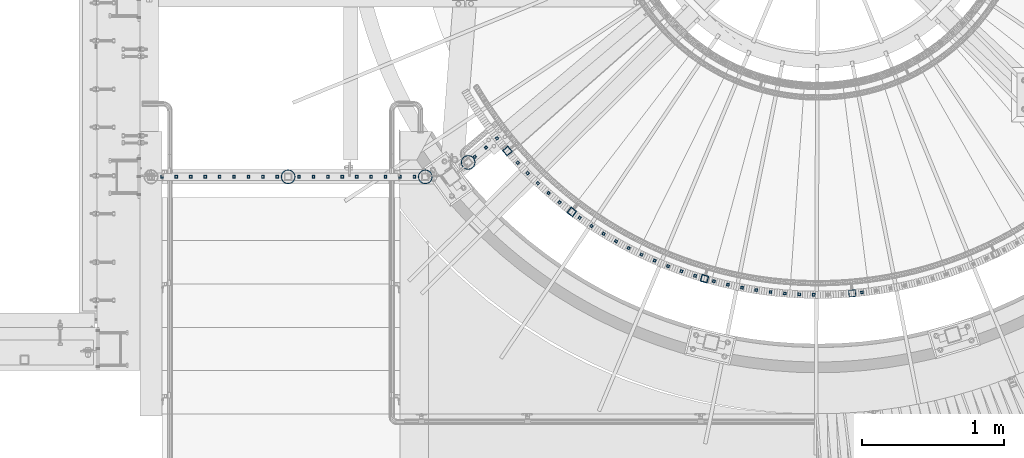
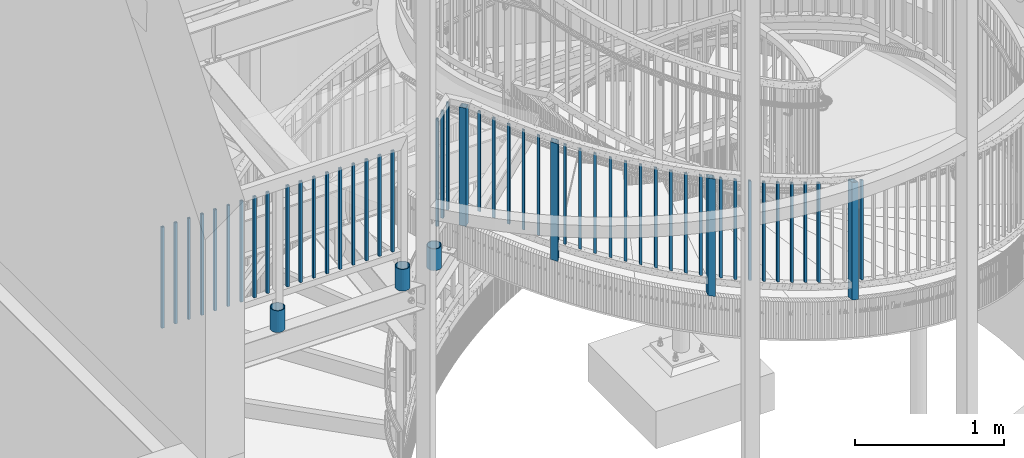
# One storey, part 254 of 975: 52 columns.
"""IFC2X3 building model written with IfcOpenShell, lengths in millimetres."""

from ifc_helpers import new_model, si_unit, frame, origin_with_axes, place, context, subcontext, project, spatial, faceted_brep, material, type_object, element, save


model = new_model("IFC2X3")

# Units and contexts
model_context = context("Model", 3, precision=1e-05, world=origin_with_axes())
body_context = subcontext(model_context, "Body", "Model", "MODEL_VIEW")
ifc_project = project(units=[si_unit("LENGTHUNIT", "METRE", prefix="MILLI"), si_unit("AREAUNIT", "SQUARE_METRE"), si_unit("VOLUMEUNIT", "CUBIC_METRE"), si_unit("MASSUNIT", "GRAM", prefix="KILO"), si_unit("TIMEUNIT", "SECOND"), si_unit("PLANEANGLEUNIT", "RADIAN"), si_unit("SOLIDANGLEUNIT", "STERADIAN"), si_unit("THERMODYNAMICTEMPERATUREUNIT", "DEGREE_CELSIUS"), si_unit("LUMINOUSINTENSITYUNIT", "LUMEN")], contexts=[model_context])

# Site, building, storey
site_placement = place(None, origin_with_axes())
site = spatial("IfcSite", under=ifc_project, at=site_placement, CompositionType="ELEMENT")
building_placement = place(site_placement, origin_with_axes())
building = spatial("IfcBuilding", under=site, at=building_placement, Name="Undefined", CompositionType="ELEMENT")
storey_placement = place(building_placement, origin_with_axes())
storey = spatial("IfcBuildingStorey", under=building, at=storey_placement, Name="Undefined", CompositionType="ELEMENT", Elevation=0.0)

# Columns
ifc_material_1 = material()
column_type_1 = type_object("IfcColumnType", Name="HSS3/4X3/4X.120_TUBES", PredefinedType="NOTDEFINED")
for number, where, z_axis, x_axis, name in (
    (1, (32472.7728355411, 1636.53479367322, 4229.09995262131), (-0.765022466002439, -0.644003592002053, 0.0), (0.0, 0.0, 1.0), "PICKET"),
    (2, (32395.0465529952, 1571.10402872579, 4229.09995262131), (-0.765022466002439, -0.644003592002053, 0.0), (0.0, 0.0, 1.0), "PICKET"),
    (3, (32317.3202704494, 1505.67326377838, 4229.09995262131), (-0.765022466002439, -0.644003592002053, 0.0), (0.0, 0.0, 1.0), "PICKET"),
):
    element("IfcColumn", number, at=place(storey_placement, frame(where, z_axis=z_axis, x_axis=x_axis)), inside=storey, type_object=column_type_1, material=ifc_material_1, Name=name, ObjectType="HSS3/4X3/4X.120_TUBES", context=body_context, shape_type="Brep", body=[
        faceted_brep([(0.0, 6.34999999998763, -6.34999999998763), (0.0, -6.35000000000582, -6.34999999998763), (876.3, -6.35000000000218, -6.3500000000131), (876.3, 6.34999999999854, -6.35000000000946), (0.0, -6.34999999998763, 6.34999999998763), (876.3, -6.34999999999854, 6.34999999999127), (0.0, 6.35000000000946, 6.34999999998763), (876.3, 6.35000000000582, 6.34999999999491), (0.0, 9.52499999997963, -9.52499999997963), (0.0, 9.52500000000873, 9.5249999999869), (876.3, 9.52500000000146, 9.52499999999418), (876.3, 9.52499999999782, -9.52500000001237), (0.0, -9.52499999997963, 9.52499999998327), (876.3, -9.52499999999782, 9.52499999999054), (0.0, -9.52500000000873, -9.5249999999869), (876.3, -9.52500000000146, -9.52500000001237)], [[[0, 1, 2, 3]], [[1, 4, 5, 2]], [[4, 6, 7, 5]], [[6, 0, 3, 7]], [[8, 9, 10, 11]], [[9, 12, 13, 10]], [[12, 14, 15, 13]], [[14, 8, 11, 15]], [[13, 15, 11, 10], [5, 7, 3, 2]], [[14, 12, 9, 8], [6, 4, 1, 0]]]),
    ])
for number, where, z_axis, x_axis, name in (
    (4, (32618.921052414, 1464.08237529478, 4224.3312401068), (-0.736967996847281, -0.675927637859931, 0.0), (0.0, 0.0, 1.0), "PICKET"),
    (5, (32688.8815704204, 1390.43131860672, 4192.1843651068), (-0.712586748242553, -0.701584012238808, 0.0), (0.0, 0.0, 1.0), "PICKET"),
    (6, (32761.4046241084, 1319.30214797491, 4159.8390531068), (-0.687312845930432, -0.726361515926478, 0.0), (0.0, 0.0, 1.0), "PICKET"),
    (7, (32836.3993642215, 1250.78396654568, 4127.6921781068), (-0.66117795031155, -0.750229110353509, 0.0), (0.0, 0.0, 1.0), "PICKET"),
    (8, (32913.7718452344, 1184.96260669257, 4095.3468661068), (-0.634214800026097, -0.773156897031811, 0.0), (0.0, 0.0, 1.0), "PICKET"),
    (9, (33055.3764509613, 1075.95161443596, 4038.5937811068), (-0.584868572966661, -0.811128073953763, 0.0), (0.0, 0.0, 1.0), "PICKET"),
    (10, (34001.0576996427, 628.808966037676, 3704.2368493963), (-0.255339545942544, -0.966851444782421, 0.0), (0.0, 0.0, 1.0), "PICKET"),
    (11, (35044.1809236989, 550.155456184198, 3369.73696094143), (0.10810760998162, -0.994139197830999, 0.0), (0.0, 0.0, 1.0), "PICKET"),
    (12, (33138.7987237243, 1017.98889677892, 4006.2484691068), (-0.55579813310099, -0.831317289151052, 0.0), (0.0, 0.0, 1.0), "PICKET"),
    (13, (34099.7110809052, 604.591976202849, 3671.8915373963), (-0.220964785922006, -0.975281786655755, 0.0), (0.0, 0.0, 1.0), "PICKET"),
    (14, (33224.2199232644, 963.014621883565, 3973.9031571068), (-0.526031448126563, -0.850465117204621, 0.0), (0.0, 0.0, 1.0), "PICKET"),
    (15, (34199.1596589761, 583.881289326423, 3639.5462253963), (-0.186313223072022, -0.982490398379809, 0.0), (0.0, 0.0, 1.0), "PICKET"),
    (16, (33311.5330428842, 911.097655741369, 3941.5578451068), (-0.495605806811865, -0.868547571670292, 0.0), (0.0, 0.0, 1.0), "PICKET"),
    (17, (34299.2788551328, 566.702849579355, 3607.2009133963), (-0.151428267050898, -0.988468249332249, 0.0), (0.0, 0.0, 1.0), "PICKET"),
    (18, (33400.6287058876, 862.30303446887, 3909.2125331068), (-0.464559322187641, -0.885542001357677, 0.0), (0.0, 0.0, 1.0), "PICKET"),
    (19, (34399.9432505731, 553.078176304787, 3574.8556013963), (-0.116353618016888, -0.99320785114415, 0.0), (0.0, 0.0, 1.0), "PICKET"),
    (20, (33491.3953025959, 816.691882837225, 3876.8672211068), (-0.432930886148133, -0.901427117308433, 0.0), (0.0, 0.0, 1.0), "PICKET"),
    (21, (34501.0267435266, 543.024337060864, 3542.5102893963), (-0.0811332129715956, -0.996703266651066, 0.0), (0.0, 0.0, 1.0), "PICKET"),
    (22, (33583.7191301599, 774.321337701564, 3844.5219091068), (-0.400760120016283, -0.916183020037228, 0.0), (0.0, 0.0, 1.0), "PICKET"),
    (23, (34602.4027072213, 536.553926240314, 3510.1649773963), (-0.0458111720060842, -0.998950117132697, 0.0), (0.0, 0.0, 1.0), "PICKET"),
    (24, (33677.4845349956, 735.244476425897, 3812.1765971068), (-0.36808732396752, -0.929791224917954, 0.0), (0.0, 0.0, 1.0), "PICKET"),
    (25, (34703.9441485088, 533.675049293503, 3477.8196653963), (-0.0104317449986193, -0.999945587867802, 0.0), (0.0, 0.0, 1.0), "PICKET"),
    (26, (33772.5740576626, 699.510250393418, 3779.8312851068), (-0.334953427020751, -0.942234685058375, 0.0), (0.0, 0.0, 1.0), "PICKET"),
    (27, (33868.8685800047, 667.163423685329, 3747.4859731068), (-0.301399934967783, -0.953497812898077, 0.0), (0.0, 0.0, 1.0), "PICKET"),
):
    element("IfcColumn", number, at=place(storey_placement, frame(where, z_axis=z_axis, x_axis=x_axis)), inside=storey, type_object=column_type_1, material=ifc_material_1, Name=name, ObjectType="HSS3/4X3/4X.120_TUBES", context=body_context, shape_type="Brep", body=[
        faceted_brep([(48.9778304891588, 6.35000000000036, -6.34999999999854), (44.9444858438005, -6.35000000000582, -6.34999999999127), (858.946568247068, -6.35000000000582, -6.34999999999127), (863.063419332087, 6.35000000000036, -6.34999999999854), (44.9444858438051, -6.35000000000036, 6.35000000000582), (858.946568247072, -6.35000000000036, 6.35000000000582), (48.9778304891634, 6.350000000004, 6.34999999999854), (863.063419332091, 6.350000000004, 6.34999999999854), (49.9861666504976, 9.52499999999964, -9.52500000000146), (49.9861666505039, 9.52500000000691, 9.52499999999418), (864.092632103347, 9.52500000000691, 9.52499999999418), (864.09263210334, 9.52499999999964, -9.52500000000146), (43.9361496824667, -9.52500000000146, 9.52500000001601), (857.917355475819, -9.52500000000146, 9.52500000001601), (43.9361496824599, -9.52500000000691, -9.52499999997963), (857.917355475812, -9.52500000000691, -9.52499999997963)], [[[0, 1, 2, 3]], [[1, 4, 5, 2]], [[4, 6, 7, 5]], [[6, 0, 3, 7]], [[8, 9, 10, 11]], [[9, 12, 13, 10]], [[12, 14, 15, 13]], [[14, 8, 11, 15]], [[13, 15, 11, 10], [5, 7, 3, 2]], [[14, 12, 9, 8], [6, 4, 1, 0]]]),
    ])
for number, where, z_axis, x_axis, name in (
    (28, (31890.8704303168, 1364.92410933259, 4254.49990684305), (1.0, 0.0, 0.0), (0.0, 0.0, 1.0), "PICKET"),
    (29, (31789.2704303168, 1364.92410933259, 4254.49990684305), (1.0, 0.0, 0.0), (0.0, 0.0, 1.0), "PICKET"),
    (30, (31687.6704303168, 1364.92410933259, 4254.49990684305), (1.0, 0.0, 0.0), (0.0, 0.0, 1.0), "PICKET"),
    (31, (31586.0704303168, 1364.92410933259, 4254.49990684305), (1.0, 0.0, 0.0), (0.0, 0.0, 1.0), "PICKET"),
    (32, (31484.4704303168, 1364.92410933259, 4254.49990684305), (1.0, 0.0, 0.0), (0.0, 0.0, 1.0), "PICKET"),
    (33, (31382.8704303168, 1364.92410933259, 4254.49990684305), (1.0, 0.0, 0.0), (0.0, 0.0, 1.0), "PICKET"),
    (34, (31281.2704303168, 1364.92410933259, 4254.49990684305), (1.0, 0.0, 0.0), (0.0, 0.0, 1.0), "PICKET"),
    (35, (31179.6704303168, 1364.92410933259, 4254.49990684305), (1.0, 0.0, 0.0), (0.0, 0.0, 1.0), "PICKET"),
    (36, (31078.0704303168, 1364.92410933259, 4254.49990684305), (1.0, 0.0, 0.0), (0.0, 0.0, 1.0), "PICKET"),
    (37, (30924.8901221104, 1364.93166525738, 4254.49996145182), (1.0, 0.0, 0.0), (0.0, 0.0, 1.0), "PICKET"),
    (38, (30823.2901221104, 1364.93166525738, 4254.49996145182), (1.0, 0.0, 0.0), (0.0, 0.0, 1.0), "PICKET"),
    (39, (30721.6901221104, 1364.93166525738, 4254.49996145182), (1.0, 0.0, 0.0), (0.0, 0.0, 1.0), "PICKET"),
    (40, (30620.0901221104, 1364.93166525738, 4254.49996145182), (1.0, 0.0, 0.0), (0.0, 0.0, 1.0), "PICKET"),
    (41, (30518.4901221104, 1364.93166525738, 4254.49996145182), (1.0, 0.0, 0.0), (0.0, 0.0, 1.0), "PICKET"),
    (42, (30416.8901221104, 1364.93166525738, 4254.49996145182), (1.0, 0.0, 0.0), (0.0, 0.0, 1.0), "PICKET"),
    (43, (30315.2901221104, 1364.93166525738, 4254.49996145182), (1.0, 0.0, 0.0), (0.0, 0.0, 1.0), "PICKET"),
    (44, (30213.6901221104, 1364.93166525738, 4254.49996145182), (1.0, 0.0, 0.0), (0.0, 0.0, 1.0), "PICKET"),
    (45, (30112.0901221104, 1364.93166525738, 4254.49996145182), (1.0, 0.0, 0.0), (0.0, 0.0, 1.0), "PICKET"),
):
    element("IfcColumn", number, at=place(storey_placement, frame(where, z_axis=z_axis, x_axis=x_axis)), inside=storey, type_object=column_type_1, material=ifc_material_1, Name=name, ObjectType="HSS3/4X3/4X.120_TUBES", context=body_context, shape_type="Brep", body=[
        faceted_brep([(0.0, 6.34999999998763, -6.34999999998763), (0.0, -6.35000000000582, -6.34999999998763), (825.49997943247, -6.35000000000582, -6.34999999998763), (825.49997943247, 6.34999999998763, -6.34999999998763), (0.0, -6.34999999998763, 6.34999999998763), (825.49997943247, -6.34999999998763, 6.34999999998763), (0.0, 6.35000000000946, 6.34999999998763), (825.49997943247, 6.35000000000946, 6.34999999998763), (0.0, 9.52499999997963, -9.52499999997963), (0.0, 9.52500000000873, 9.5249999999869), (825.49997943247, 9.52500000000873, 9.5249999999869), (825.49997943247, 9.52499999997963, -9.52499999997963), (0.0, -9.52499999997963, 9.52499999998327), (825.49997943247, -9.52499999997963, 9.52499999998327), (0.0, -9.52500000000873, -9.5249999999869), (825.49997943247, -9.52500000000873, -9.5249999999869)], [[[0, 1, 2, 3]], [[1, 4, 5, 2]], [[4, 6, 7, 5]], [[6, 0, 3, 7]], [[8, 9, 10, 11]], [[9, 12, 13, 10]], [[12, 14, 15, 13]], [[14, 8, 11, 15]], [[13, 15, 11, 10], [5, 7, 3, 2]], [[14, 12, 9, 8], [6, 4, 1, 0]]]),
    ])
column_type_2 = type_object("IfcColumnType", Name="HSS2X2X.188_TUBES", PredefinedType="NOTDEFINED")
for number, where, z_axis, x_axis, name in (
    (46, (32999.9820526721, 1116.79097201019, 3906.48311287522), (-0.604319542031932, -0.796742048042098, 0.0), (0.0, 0.0, 1.0), "HANDRAIL"),
    (47, (33934.7070575041, 647.084212052728, 3572.11593587522), (-0.278654082022891, -0.960391536078895, 0.0), (0.0, 0.0, 1.0), "HANDRAIL"),
    (48, (34975.6758745477, 543.550658189336, 3237.55032187522), (0.0840275489872219, -0.996463431848455, 0.0), (0.0, 0.0, 1.0), "HANDRAIL"),
):
    element("IfcColumn", number, at=place(storey_placement, frame(where, z_axis=z_axis, x_axis=x_axis)), inside=storey, type_object=column_type_2, material=ifc_material_1, Name=name, ObjectType="HSS2X2X.188_TUBES", context=body_context, shape_type="Brep", body=[
        faceted_brep([(59.7770034089217, 20.6374999999425, -20.6375000000444), (46.6339334019876, -20.6375000000517, -20.6375000000335), (1006.79125658838, -20.6375000000517, -20.6375000000335), (1019.96851403156, 20.6374999999425, -20.6375000000444), (46.6339334020035, -20.6374999999389, 20.637500000048), (1006.7912565884, -20.6374999999389, 20.637500000048), (59.7770034089381, 20.6375000000517, 20.6375000000335), (1019.96851403158, 20.6375000000517, 20.6375000000335), (61.2935114866432, 25.3999999999287, -25.4000000000524), (61.2935114866632, 25.4000000000633, 25.4000000000415), (1021.48896681348, 25.4000000000633, 25.4000000000415), (1021.48896681346, 25.3999999999287, -25.4000000000524), (45.1174253242825, -25.3999999999251, 25.400000000056), (1005.27080380649, -25.3999999999251, 25.400000000056), (45.1174253242625, -25.4000000000597, -25.4000000000415), (1005.27080380647, -25.4000000000597, -25.4000000000415)], [[[0, 1, 2, 3]], [[1, 4, 5, 2]], [[4, 6, 7, 5]], [[6, 0, 3, 7]], [[8, 9, 10, 11]], [[9, 12, 13, 10]], [[12, 14, 15, 13]], [[14, 8, 11, 15]], [[13, 15, 11, 10], [5, 7, 3, 2]], [[14, 12, 9, 8], [6, 4, 1, 0]]]),
    ])
column_1_placement = place(storey_placement, frame((32546.1374942593, 1546.41999163571, 4089.4), z_axis=(-0.762442511287587, -0.647055961244063, 0.0), x_axis=(0.0, 0.0, 1.0)))
element("IfcColumn", 49, at=column_1_placement, inside=storey, type_object=column_type_2, material=ifc_material_1, Name="HANDRAIL", ObjectType="HSS2X2X.188_TUBES", context=body_context, shape_type="Brep", body=[
    faceted_brep([(51.3320176729967, 20.6374999999716, -20.6375000000371), (51.3320175904473, -20.6374999999935, -20.6374999999898), (1016.0, -20.6374999999935, -20.6374999999898), (1016.0, 20.6374999999716, -20.6375000000371), (51.3320175904473, -20.6374999999716, 20.6375000000226), (1016.0, -20.6374999999716, 20.6375000000226), (51.3320176729967, 20.6374999999898, 20.6374999999789), (1016.0, 20.6374999999898, 20.6374999999789), (51.3320176825218, 25.3999999999651, -25.4000000000415), (51.3320176825218, 25.3999999999869, 25.3999999999724), (1016.00000000002, 25.4000000000087, 25.3999999999724), (1016.0, 25.3999999999651, -25.4000000000415), (51.3320175809222, -25.3999999999687, 25.4000000000306), (1016.00000000003, -25.4000000000087, 25.4000000000124), (51.3320175809222, -25.3999999999869, -25.3999999999833), (1016.0, -25.3999999999869, -25.3999999999833)], [[[0, 1, 2, 3]], [[1, 4, 5, 2]], [[4, 6, 7, 5]], [[6, 0, 3, 7]], [[8, 9, 10, 11]], [[9, 12, 13, 10]], [[12, 14, 15, 13]], [[14, 8, 11, 15]], [[13, 15, 11, 10], [5, 7, 3, 2]], [[14, 12, 9, 8], [6, 4, 1, 0]]]),
])
ifc_material_2 = material(Name="STEEL/A53")
column_type_3 = type_object("IfcColumnType", Name="PIPE3-1/2STD", PredefinedType="NOTDEFINED")
column_2_placement = place(storey_placement, frame((32269.6346224354, 1465.92800353304, 3936.99998820788), z_axis=(-0.765022466002439, -0.644003592002053, 0.0), x_axis=(0.0, 0.0, 1.0)))
element("IfcColumn", 50, at=column_2_placement, inside=storey, type_object=column_type_3, material=ifc_material_2, ObjectType="PIPE3-1/2STD", context=body_context, shape_type="Brep", body=[
    faceted_brep([(0.0, -45.0595999999932, 1.45519152283669e-11), (0.0, -42.8542262016344, 13.924182159768), (177.8, -42.8542262016344, 13.924182159768), (177.8, -45.0595999999932, 1.45519152283669e-11), (0.0, -36.45398215971, 26.4853683542424), (177.8, -36.45398215971, 26.4853683542424), (0.0, -26.4853683541623, 36.45398215979), (177.8, -26.4853683541623, 36.45398215979), (0.0, -13.9241821596988, 42.8542262017108), (177.8, -13.9241821596988, 42.8542262017108), (0.0, 3.63797880709171e-11, 45.0596000000514), (177.8, 3.63797880709171e-11, 45.0596000000514), (0.0, 13.9241821597716, 42.8542262017036), (177.8, 13.9241821597716, 42.8542262017036), (0.0, 26.4853683542242, 36.4539821597718), (177.8, 26.4853683542242, 36.4539821597718), (0.0, 36.4539821597537, 26.4853683542206), (177.8, 36.4539821597537, 26.4853683542206), (0.0, 42.8542262016563, 13.9241821597425), (177.8, 42.8542262016563, 13.9241821597425), (0.0, 45.0595999999932, -1.09139364212751e-11), (177.8, 45.0595999999932, -1.09139364212751e-11), (0.0, 42.8542262016344, -13.9241821597643), (177.8, 42.8542262016344, -13.9241821597643), (0.0, 36.45398215971, -26.4853683542387), (177.8, 36.45398215971, -26.4853683542387), (0.0, 26.4853683541623, -36.4539821597864), (177.8, 26.4853683541623, -36.4539821597864), (0.0, 13.9241821596988, -42.8542262017072), (177.8, 13.9241821596988, -42.8542262017072), (0.0, -3.63797880709171e-11, -45.0596000000478), (177.8, -3.63797880709171e-11, -45.0596000000478), (0.0, -13.9241821597716, -42.8542262016963), (177.8, -13.9241821597716, -42.8542262016963), (0.0, -26.4853683542242, -36.4539821597682), (177.8, -26.4853683542242, -36.4539821597682), (0.0, -36.4539821597537, -26.4853683542169), (177.8, -36.4539821597537, -26.4853683542169), (0.0, -42.8542262016563, -13.9241821597352), (177.8, -42.8542262016563, -13.9241821597352), (0.0, -50.799999999992, 1.81898940354586e-11), (0.0, -48.3136710278013, -15.6980633142484), (177.8, -48.3136710278013, -15.6980633142484), (177.8, -50.799999999992, 1.81898940354586e-11), (0.0, -41.0980633142644, -29.8594908164741), (177.8, -41.0980633142644, -29.8594908164741), (0.0, -29.859490816485, -41.0980633142826), (177.8, -29.859490816485, -41.0980633142826), (0.0, -15.6980633142848, -48.313671027845), (177.8, -15.6980633142848, -48.313671027845), (0.0, -4.36557456851006e-11, -50.8000000000575), (177.8, -4.36557456851006e-11, -50.8000000000575), (0.0, 15.6980633142011, -48.3136710278523), (177.8, 15.6980633142011, -48.3136710278523), (0.0, 29.8594908164159, -41.0980633143045), (177.8, 29.8594908164159, -41.0980633143045), (0.0, 41.0980633142135, -29.8594908165032), (177.8, 41.0980633142135, -29.8594908165032), (0.0, 48.3136710277722, -15.6980633142775), (177.8, 48.3136710277722, -15.6980633142775), (0.0, 50.799999999992, -1.45519152283669e-11), (177.8, 50.799999999992, -1.45519152283669e-11), (0.0, 48.313671027794, 15.6980633142521), (177.8, 48.313671027794, 15.6980633142521), (0.0, 41.0980633142644, 29.8594908164814), (177.8, 41.0980633142644, 29.8594908164814), (0.0, 29.859490816485, 41.0980633142863), (177.8, 29.859490816485, 41.0980633142863), (0.0, 15.6980633142848, 48.3136710278486), (177.8, 15.6980633142848, 48.3136710278486), (0.0, 4.00177668780088e-11, 50.8000000000611), (177.8, 4.00177668780088e-11, 50.8000000000611), (0.0, -15.6980633142011, 48.3136710278559), (177.8, -15.6980633142011, 48.3136710278559), (0.0, -29.8594908164159, 41.0980633143081), (177.8, -29.8594908164159, 41.0980633143081), (0.0, -41.0980633142171, 29.8594908165069), (177.8, -41.0980633142171, 29.8594908165069), (0.0, -48.3136710277722, 15.6980633142812), (177.8, -48.3136710277722, 15.6980633142812)], [[[0, 1, 2, 3]], [[1, 4, 5, 2]], [[4, 6, 7, 5]], [[6, 8, 9, 7]], [[8, 10, 11, 9]], [[10, 12, 13, 11]], [[12, 14, 15, 13]], [[14, 16, 17, 15]], [[16, 18, 19, 17]], [[18, 20, 21, 19]], [[20, 22, 23, 21]], [[22, 24, 25, 23]], [[24, 26, 27, 25]], [[26, 28, 29, 27]], [[28, 30, 31, 29]], [[30, 32, 33, 31]], [[32, 34, 35, 33]], [[34, 36, 37, 35]], [[36, 38, 39, 37]], [[38, 0, 3, 39]], [[40, 41, 42, 43]], [[41, 44, 45, 42]], [[44, 46, 47, 45]], [[46, 48, 49, 47]], [[48, 50, 51, 49]], [[50, 52, 53, 51]], [[52, 54, 55, 53]], [[54, 56, 57, 55]], [[56, 58, 59, 57]], [[58, 60, 61, 59]], [[60, 62, 63, 61]], [[62, 64, 65, 63]], [[64, 66, 67, 65]], [[66, 68, 69, 67]], [[68, 70, 71, 69]], [[70, 72, 73, 71]], [[72, 74, 75, 73]], [[74, 76, 77, 75]], [[76, 78, 79, 77]], [[78, 40, 43, 79]], [[45, 47, 49, 51, 53, 55, 57, 59, 61, 63, 65, 67, 69, 71, 73, 75, 77, 79, 43, 42], [5, 7, 9, 11, 13, 15, 17, 19, 21, 23, 25, 27, 29, 31, 33, 35, 37, 39, 3, 2]], [[78, 76, 74, 72, 70, 68, 66, 64, 62, 60, 58, 56, 54, 52, 50, 48, 46, 44, 41, 40], [38, 36, 34, 32, 30, 28, 26, 24, 22, 20, 18, 16, 14, 12, 10, 8, 6, 4, 1, 0]]]),
])
column_3_placement = place(storey_placement, frame((31001.4794537483, 1364.92003827587, 3936.99999703592), z_axis=(1.0, 0.0, 0.0), x_axis=(0.0, 0.0, 1.0)))
element("IfcColumn", 51, at=column_3_placement, inside=storey, type_object=column_type_3, material=ifc_material_2, ObjectType="PIPE3-1/2STD", context=body_context, shape_type="Brep", body=[
    faceted_brep([(0.0, -45.0595999999932, 1.45519152283669e-11), (0.0, -42.8542262016344, 13.924182159768), (177.8, -42.8542262016344, 13.924182159768), (177.8, -45.0595999999932, 1.45519152283669e-11), (0.0, -36.45398215971, 26.4853683542424), (177.8, -36.45398215971, 26.4853683542424), (0.0, -26.4853683541623, 36.45398215979), (177.8, -26.4853683541623, 36.45398215979), (0.0, -13.9241821596988, 42.8542262017108), (177.8, -13.9241821596988, 42.8542262017108), (0.0, 3.63797880709171e-11, 45.0596000000514), (177.8, 3.63797880709171e-11, 45.0596000000514), (0.0, 13.9241821597716, 42.8542262017036), (177.8, 13.9241821597716, 42.8542262017036), (0.0, 26.4853683542242, 36.4539821597718), (177.8, 26.4853683542242, 36.4539821597718), (0.0, 36.4539821597537, 26.4853683542206), (177.8, 36.4539821597537, 26.4853683542206), (0.0, 42.8542262016563, 13.9241821597425), (177.8, 42.8542262016563, 13.9241821597425), (0.0, 45.0595999999932, -1.09139364212751e-11), (177.8, 45.0595999999932, -1.09139364212751e-11), (0.0, 42.8542262016344, -13.9241821597643), (177.8, 42.8542262016344, -13.9241821597643), (0.0, 36.45398215971, -26.4853683542387), (177.8, 36.45398215971, -26.4853683542387), (0.0, 26.4853683541623, -36.4539821597864), (177.8, 26.4853683541623, -36.4539821597864), (0.0, 13.9241821596988, -42.8542262017072), (177.8, 13.9241821596988, -42.8542262017072), (0.0, -3.63797880709171e-11, -45.0596000000478), (177.8, -3.63797880709171e-11, -45.0596000000478), (0.0, -13.9241821597716, -42.8542262016963), (177.8, -13.9241821597716, -42.8542262016963), (0.0, -26.4853683542242, -36.4539821597682), (177.8, -26.4853683542242, -36.4539821597682), (0.0, -36.4539821597537, -26.4853683542169), (177.8, -36.4539821597537, -26.4853683542169), (0.0, -42.8542262016563, -13.9241821597352), (177.8, -42.8542262016563, -13.9241821597352), (0.0, -50.799999999992, 1.81898940354586e-11), (0.0, -48.3136710278013, -15.6980633142484), (177.8, -48.3136710278013, -15.6980633142484), (177.8, -50.799999999992, 1.81898940354586e-11), (0.0, -41.0980633142644, -29.8594908164741), (177.8, -41.0980633142644, -29.8594908164741), (0.0, -29.859490816485, -41.0980633142826), (177.8, -29.859490816485, -41.0980633142826), (0.0, -15.6980633142848, -48.313671027845), (177.8, -15.6980633142848, -48.313671027845), (0.0, -4.36557456851006e-11, -50.8000000000575), (177.8, -4.36557456851006e-11, -50.8000000000575), (0.0, 15.6980633142011, -48.3136710278523), (177.8, 15.6980633142011, -48.3136710278523), (0.0, 29.8594908164159, -41.0980633143045), (177.8, 29.8594908164159, -41.0980633143045), (0.0, 41.0980633142135, -29.8594908165032), (177.8, 41.0980633142135, -29.8594908165032), (0.0, 48.3136710277722, -15.6980633142775), (177.8, 48.3136710277722, -15.6980633142775), (0.0, 50.799999999992, -1.45519152283669e-11), (177.8, 50.799999999992, -1.45519152283669e-11), (0.0, 48.313671027794, 15.6980633142521), (177.8, 48.313671027794, 15.6980633142521), (0.0, 41.0980633142644, 29.8594908164814), (177.8, 41.0980633142644, 29.8594908164814), (0.0, 29.859490816485, 41.0980633142863), (177.8, 29.859490816485, 41.0980633142863), (0.0, 15.6980633142848, 48.3136710278486), (177.8, 15.6980633142848, 48.3136710278486), (0.0, 4.00177668780088e-11, 50.8000000000611), (177.8, 4.00177668780088e-11, 50.8000000000611), (0.0, -15.6980633142011, 48.3136710278559), (177.8, -15.6980633142011, 48.3136710278559), (0.0, -29.8594908164159, 41.0980633143081), (177.8, -29.8594908164159, 41.0980633143081), (0.0, -41.0980633142171, 29.8594908165069), (177.8, -41.0980633142171, 29.8594908165069), (0.0, -48.3136710277722, 15.6980633142812), (177.8, -48.3136710277722, 15.6980633142812)], [[[0, 1, 2, 3]], [[1, 4, 5, 2]], [[4, 6, 7, 5]], [[6, 8, 9, 7]], [[8, 10, 11, 9]], [[10, 12, 13, 11]], [[12, 14, 15, 13]], [[14, 16, 17, 15]], [[16, 18, 19, 17]], [[18, 20, 21, 19]], [[20, 22, 23, 21]], [[22, 24, 25, 23]], [[24, 26, 27, 25]], [[26, 28, 29, 27]], [[28, 30, 31, 29]], [[30, 32, 33, 31]], [[32, 34, 35, 33]], [[34, 36, 37, 35]], [[36, 38, 39, 37]], [[38, 0, 3, 39]], [[40, 41, 42, 43]], [[41, 44, 45, 42]], [[44, 46, 47, 45]], [[46, 48, 49, 47]], [[48, 50, 51, 49]], [[50, 52, 53, 51]], [[52, 54, 55, 53]], [[54, 56, 57, 55]], [[56, 58, 59, 57]], [[58, 60, 61, 59]], [[60, 62, 63, 61]], [[62, 64, 65, 63]], [[64, 66, 67, 65]], [[66, 68, 69, 67]], [[68, 70, 71, 69]], [[70, 72, 73, 71]], [[72, 74, 75, 73]], [[74, 76, 77, 75]], [[76, 78, 79, 77]], [[78, 40, 43, 79]], [[45, 47, 49, 51, 53, 55, 57, 59, 61, 63, 65, 67, 69, 71, 73, 75, 77, 79, 43, 42], [5, 7, 9, 11, 13, 15, 17, 19, 21, 23, 25, 27, 29, 31, 33, 35, 37, 39, 3, 2]], [[78, 76, 74, 72, 70, 68, 66, 64, 62, 60, 58, 56, 54, 52, 50, 48, 46, 44, 41, 40], [38, 36, 34, 32, 30, 28, 26, 24, 22, 20, 18, 16, 14, 12, 10, 8, 6, 4, 1, 0]]]),
])
column_4_placement = place(storey_placement, frame((31967.5756860701, 1364.57430008261, 3937.00489548149), z_axis=(1.0, 0.0, 0.0), x_axis=(0.0, 0.0, 1.0)))
element("IfcColumn", 52, at=column_4_placement, inside=storey, type_object=column_type_3, material=ifc_material_2, ObjectType="PIPE3-1/2STD", context=body_context, shape_type="Brep", body=[
    faceted_brep([(0.0, -45.0595999999932, 1.45519152283669e-11), (0.0, -42.8542262016344, 13.924182159768), (177.8, -42.8542262016344, 13.924182159768), (177.8, -45.0595999999932, 1.45519152283669e-11), (0.0, -36.45398215971, 26.4853683542424), (177.8, -36.45398215971, 26.4853683542424), (0.0, -26.4853683541623, 36.45398215979), (177.8, -26.4853683541623, 36.45398215979), (0.0, -13.9241821596988, 42.8542262017108), (177.8, -13.9241821596988, 42.8542262017108), (0.0, 3.63797880709171e-11, 45.0596000000514), (177.8, 3.63797880709171e-11, 45.0596000000514), (0.0, 13.9241821597716, 42.8542262017036), (177.8, 13.9241821597716, 42.8542262017036), (0.0, 26.4853683542242, 36.4539821597718), (177.8, 26.4853683542242, 36.4539821597718), (0.0, 36.4539821597537, 26.4853683542206), (177.8, 36.4539821597537, 26.4853683542206), (0.0, 42.8542262016563, 13.9241821597425), (177.8, 42.8542262016563, 13.9241821597425), (0.0, 45.0595999999932, -1.09139364212751e-11), (177.8, 45.0595999999932, -1.09139364212751e-11), (0.0, 42.8542262016344, -13.9241821597643), (177.8, 42.8542262016344, -13.9241821597643), (0.0, 36.45398215971, -26.4853683542387), (177.8, 36.45398215971, -26.4853683542387), (0.0, 26.4853683541623, -36.4539821597864), (177.8, 26.4853683541623, -36.4539821597864), (0.0, 13.9241821596988, -42.8542262017072), (177.8, 13.9241821596988, -42.8542262017072), (0.0, -3.63797880709171e-11, -45.0596000000478), (177.8, -3.63797880709171e-11, -45.0596000000478), (0.0, -13.9241821597716, -42.8542262016963), (177.8, -13.9241821597716, -42.8542262016963), (0.0, -26.4853683542242, -36.4539821597682), (177.8, -26.4853683542242, -36.4539821597682), (0.0, -36.4539821597537, -26.4853683542169), (177.8, -36.4539821597537, -26.4853683542169), (0.0, -42.8542262016563, -13.9241821597352), (177.8, -42.8542262016563, -13.9241821597352), (0.0, -50.799999999992, 1.81898940354586e-11), (0.0, -48.3136710278013, -15.6980633142484), (177.8, -48.3136710278013, -15.6980633142484), (177.8, -50.799999999992, 1.81898940354586e-11), (0.0, -41.0980633142644, -29.8594908164741), (177.8, -41.0980633142644, -29.8594908164741), (0.0, -29.859490816485, -41.0980633142826), (177.8, -29.859490816485, -41.0980633142826), (0.0, -15.6980633142848, -48.313671027845), (177.8, -15.6980633142848, -48.313671027845), (0.0, -4.36557456851006e-11, -50.8000000000575), (177.8, -4.36557456851006e-11, -50.8000000000575), (0.0, 15.6980633142011, -48.3136710278523), (177.8, 15.6980633142011, -48.3136710278523), (0.0, 29.8594908164159, -41.0980633143045), (177.8, 29.8594908164159, -41.0980633143045), (0.0, 41.0980633142135, -29.8594908165032), (177.8, 41.0980633142135, -29.8594908165032), (0.0, 48.3136710277722, -15.6980633142775), (177.8, 48.3136710277722, -15.6980633142775), (0.0, 50.799999999992, -1.45519152283669e-11), (177.8, 50.799999999992, -1.45519152283669e-11), (0.0, 48.313671027794, 15.6980633142521), (177.8, 48.313671027794, 15.6980633142521), (0.0, 41.0980633142644, 29.8594908164814), (177.8, 41.0980633142644, 29.8594908164814), (0.0, 29.859490816485, 41.0980633142863), (177.8, 29.859490816485, 41.0980633142863), (0.0, 15.6980633142848, 48.3136710278486), (177.8, 15.6980633142848, 48.3136710278486), (0.0, 4.00177668780088e-11, 50.8000000000611), (177.8, 4.00177668780088e-11, 50.8000000000611), (0.0, -15.6980633142011, 48.3136710278559), (177.8, -15.6980633142011, 48.3136710278559), (0.0, -29.8594908164159, 41.0980633143081), (177.8, -29.8594908164159, 41.0980633143081), (0.0, -41.0980633142171, 29.8594908165069), (177.8, -41.0980633142171, 29.8594908165069), (0.0, -48.3136710277722, 15.6980633142812), (177.8, -48.3136710277722, 15.6980633142812)], [[[0, 1, 2, 3]], [[1, 4, 5, 2]], [[4, 6, 7, 5]], [[6, 8, 9, 7]], [[8, 10, 11, 9]], [[10, 12, 13, 11]], [[12, 14, 15, 13]], [[14, 16, 17, 15]], [[16, 18, 19, 17]], [[18, 20, 21, 19]], [[20, 22, 23, 21]], [[22, 24, 25, 23]], [[24, 26, 27, 25]], [[26, 28, 29, 27]], [[28, 30, 31, 29]], [[30, 32, 33, 31]], [[32, 34, 35, 33]], [[34, 36, 37, 35]], [[36, 38, 39, 37]], [[38, 0, 3, 39]], [[40, 41, 42, 43]], [[41, 44, 45, 42]], [[44, 46, 47, 45]], [[46, 48, 49, 47]], [[48, 50, 51, 49]], [[50, 52, 53, 51]], [[52, 54, 55, 53]], [[54, 56, 57, 55]], [[56, 58, 59, 57]], [[58, 60, 61, 59]], [[60, 62, 63, 61]], [[62, 64, 65, 63]], [[64, 66, 67, 65]], [[66, 68, 69, 67]], [[68, 70, 71, 69]], [[70, 72, 73, 71]], [[72, 74, 75, 73]], [[74, 76, 77, 75]], [[76, 78, 79, 77]], [[78, 40, 43, 79]], [[45, 47, 49, 51, 53, 55, 57, 59, 61, 63, 65, 67, 69, 71, 73, 75, 77, 79, 43, 42], [5, 7, 9, 11, 13, 15, 17, 19, 21, 23, 25, 27, 29, 31, 33, 35, 37, 39, 3, 2]], [[78, 76, 74, 72, 70, 68, 66, 64, 62, 60, 58, 56, 54, 52, 50, 48, 46, 44, 41, 40], [38, 36, 34, 32, 30, 28, 26, 24, 22, 20, 18, 16, 14, 12, 10, 8, 6, 4, 1, 0]]]),
])

save(model, "model.ifc")
